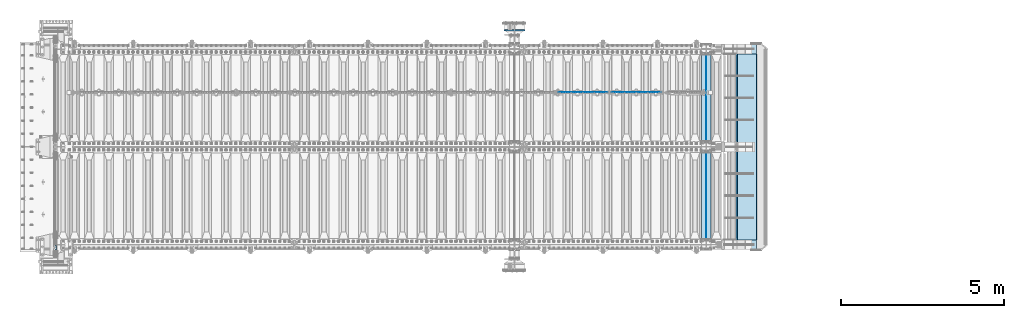
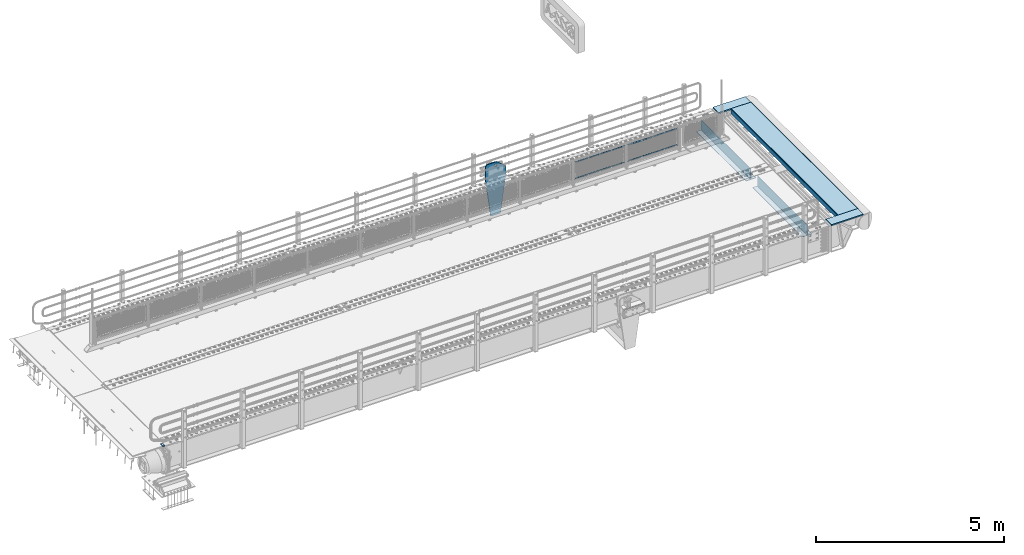
# One storey, part 194 of 242: 14 plates.
"""IFC2X3 building model written with IfcOpenShell, lengths in millimetres."""

from ifc_helpers import new_model, si_unit, frame, origin_with_axes, place, context, subcontext, project, spatial, faceted_brep, material, type_object, element, save


model = new_model("IFC2X3")

# Units and contexts
model_context = context("Model", 3, precision=1e-05, world=origin_with_axes())
body_context = subcontext(model_context, "Body", "Model", "MODEL_VIEW")
ifc_project = project(units=[si_unit("LENGTHUNIT", "METRE", prefix="MILLI"), si_unit("AREAUNIT", "SQUARE_METRE"), si_unit("VOLUMEUNIT", "CUBIC_METRE"), si_unit("MASSUNIT", "GRAM", prefix="KILO"), si_unit("TIMEUNIT", "SECOND"), si_unit("PLANEANGLEUNIT", "RADIAN"), si_unit("SOLIDANGLEUNIT", "STERADIAN"), si_unit("THERMODYNAMICTEMPERATUREUNIT", "DEGREE_CELSIUS"), si_unit("LUMINOUSINTENSITYUNIT", "LUMEN")], contexts=[model_context])

# Site, building, storey
site_placement = place(None, origin_with_axes())
site = spatial("IfcSite", under=ifc_project, at=site_placement, CompositionType="ELEMENT")
building_placement = place(site_placement, origin_with_axes())
building = spatial("IfcBuilding", under=site, at=building_placement, Name="Standard", CompositionType="ELEMENT")
storey_placement = place(building_placement, origin_with_axes())
storey = spatial("IfcBuildingStorey", under=building, at=storey_placement, Name="Undefined", CompositionType="ELEMENT", Elevation=0.0)

# Plates
ifc_material_1 = material()
plate_type_1 = type_object("IfcPlateType", PredefinedType="NOTDEFINED")
plate_1_placement = place(storey_placement, frame((-42460.00000006, -24089.9999995681, -15.9997623857934), z_axis=(-1.0, 0.0, 0.0), x_axis=(0.0, -4.95099997756316e-06, 0.999999999987744)))
element("IfcPlate", 1, at=plate_1_placement, inside=storey, type_object=plate_type_1, material=ifc_material_1, context=body_context, shape_type="Brep", body=[
    faceted_brep([(-1.77635683940025e-15, -60.0, 0.0), (-0.000933120085690575, -60.0, 60.0), (-0.000933120085690575, 60.0, 59.9999999999927), (-1.77635683940025e-15, 60.0, -7.27595761418343e-12), (24.9991450303709, -60.0, 60.0), (24.9991450303709, 60.0, 59.9999999999927), (26.544215218168, -60.0000000000036, 59.7552873850873), (26.544215218168, 60.0, 59.75528738508), (27.9380461396139, -60.0000000000036, 59.0451032459096), (27.9380461396139, 60.0, 59.0451032459096), (29.0442025908961, -60.0000000000036, 57.9389639895744), (29.0442025908961, 60.0, 57.9389639895744), (29.7544083969366, -60.0, 56.5451441080368), (29.7544083969366, 60.0, 56.5451441080295), (29.9991450297669, -60.0000000000036, 55.0000777244568), (29.9991450297669, 60.0, 55.0000777244495), (29.999922274335, -60.0, 5.00007772445679), (29.999922274335, 59.9999999999964, 5.00007772444951), (29.7552240705896, -60.0, 3.45497416452417), (29.7552240705896, 60.0000000000036, 3.45497416452417), (29.0450346578116, -60.0, 2.06111146690819), (29.0450346578116, 59.9999999999964, 2.06111146690819), (27.9388736885072, -60.0000000000036, 0.954933302316931), (27.9388736885072, 59.9999999999964, 0.954933302316931), (26.5450220308766, -60.0000000000036, 0.244722222181736), (26.5450220308766, 60.0, 0.244722222181736), (24.9999222749392, -60.0, 0.0), (24.9999222749392, 60.0, -7.27595761418343e-12)], [[[0, 1, 2, 3]], [[1, 4, 5, 2]], [[4, 6, 7, 5]], [[6, 8, 9, 7]], [[8, 10, 11, 9]], [[10, 12, 13, 11]], [[12, 14, 15, 13]], [[14, 16, 17, 15]], [[16, 18, 19, 17]], [[18, 20, 21, 19]], [[20, 22, 23, 21]], [[22, 24, 25, 23]], [[24, 26, 27, 25]], [[26, 0, 3, 27]], [[5, 7, 9, 11, 13, 15, 17, 19, 21, 23, 25, 27, 3, 2]], [[26, 24, 22, 20, 18, 16, 14, 12, 10, 8, 6, 4, 1, 0]]]),
])
ifc_material_2 = material(Name="Misc_Undefined")
plate_type_2 = type_object("IfcPlateType", PredefinedType="NOTDEFINED")
plate_2_placement = place(storey_placement, frame((-25445.4949882696, -19329.5, 351.520303374641), z_axis=(0.0, 0.0, 1.0), x_axis=(1.0, 0.0, 0.0)))
element("IfcPlate", 2, at=plate_2_placement, inside=storey, type_object=plate_type_2, material=ifc_material_2, context=body_context, shape_type="Brep", body=[
    faceted_brep([(0.0, -1.50000000000364, 0.0), (35.0002975463867, -1.5, 34.9996948242188), (35.0002975463867, 1.5, 34.9996948242188), (-3.63797880709171e-12, 1.49999999999636, 0.0), (1490.99035644531, -1.5, 34.9999923706055), (1490.99035644531, 1.5, 34.9999923706055), (1525.98999023438, -1.5, 2.81374923361e-11), (1525.98999023438, 1.5, 2.81374923361e-11)], [[[0, 1, 2, 3]], [[1, 4, 5, 2]], [[4, 6, 7, 5]], [[6, 0, 3, 7]], [[5, 7, 3, 2]], [[6, 4, 1, 0]]]),
])
plate_3_placement = place(storey_placement, frame((-23919.4999998124, -19329.5, 914.520000175701), z_axis=(-0.707103624179499, 0.0, 0.707109938179501), x_axis=(-0.707109938179495, 0.0, -0.707103624179505)))
element("IfcPlate", 3, at=plate_3_placement, inside=storey, type_object=plate_type_2, material=ifc_material_2, context=body_context, shape_type="Brep", body=[
    faceted_brep([(0.0, -1.50000000000364, 0.0), (1079.04980468751, -1.5, 1079.04028320313), (1079.04980468751, 1.5, 1079.04028320313), (-3.63797880709171e-12, 1.49999999999636, 0.0), (1079.04272460939, -1.5, 1029.53576660157), (1079.04272460939, 1.5, 1029.53576660157), (49.4976959228534, -1.5, -3.63797880709171e-12), (49.4976959228534, 1.5, -3.63797880709171e-12)], [[[0, 1, 2, 3]], [[1, 4, 5, 2]], [[4, 6, 7, 5]], [[6, 0, 3, 7]], [[5, 7, 3, 2]], [[6, 4, 1, 0]]]),
])
plate_4_placement = place(storey_placement, frame((-27078.4949882696, -19329.5, 351.520303374641), z_axis=(0.0, 0.0, 1.0), x_axis=(1.0, 0.0, 0.0)))
element("IfcPlate", 4, at=plate_4_placement, inside=storey, type_object=plate_type_2, material=ifc_material_2, context=body_context, shape_type="Brep", body=[
    faceted_brep([(0.0, -1.50000000000364, 0.0), (35.0002975463867, -1.5, 34.9996948242188), (35.0002975463867, 1.5, 34.9996948242188), (-3.63797880709171e-12, 1.49999999999636, 0.0), (1490.99035644531, -1.5, 34.9999923706055), (1490.99035644531, 1.5, 34.9999923706055), (1525.98999023438, -1.5, 2.81374923361e-11), (1525.98999023438, 1.5, 2.81374923361e-11)], [[[0, 1, 2, 3]], [[1, 4, 5, 2]], [[4, 6, 7, 5]], [[6, 0, 3, 7]], [[5, 7, 3, 2]], [[6, 4, 1, 0]]]),
])
plate_5_placement = place(storey_placement, frame((-25552.4999998124, -19329.5, 914.520000175701), z_axis=(-0.707103624179499, 0.0, 0.707109938179501), x_axis=(-0.707109938179495, 0.0, -0.707103624179505)))
element("IfcPlate", 5, at=plate_5_placement, inside=storey, type_object=plate_type_2, material=ifc_material_2, context=body_context, shape_type="Brep", body=[
    faceted_brep([(0.0, -1.50000000000364, 0.0), (1079.04980468751, -1.5, 1079.04028320313), (1079.04980468751, 1.5, 1079.04028320313), (-3.63797880709171e-12, 1.49999999999636, 0.0), (1079.04272460939, -1.5, 1029.53576660157), (1079.04272460939, 1.5, 1029.53576660157), (49.4976959228534, -1.5, -3.63797880709171e-12), (49.4976959228534, 1.5, -3.63797880709171e-12)], [[[0, 1, 2, 3]], [[1, 4, 5, 2]], [[4, 6, 7, 5]], [[6, 0, 3, 7]], [[5, 7, 3, 2]], [[6, 4, 1, 0]]]),
])
ifc_material_3 = material(Name="STEEL/S355N")
plate_type_3 = type_object("IfcPlateType", PredefinedType="NOTDEFINED")
plate_6_placement = place(storey_placement, frame((-28265.0000000603, -17419.9999999654, -1480.00001822199), z_axis=(0.0, 0.0, 1.0), x_axis=(-1.0, 0.0, 0.0)))
element("IfcPlate", 6, at=plate_6_placement, inside=storey, type_object=plate_type_3, material=ifc_material_3, context=body_context, shape_type="Brep", body=[
    faceted_brep([(113.04481869996, -15.0, 1615.3073372946), (113.04481869996, 14.9999999999527, 1615.3073372946), (121.715728752948, 14.9999999999527, 1628.28427124746), (121.715728752948, -15.0, 1628.28427124746), (134.692662705809, 14.9999999999527, 1636.95518130045), (134.692662705809, -15.0, 1636.95518130045), (150.000000000411, 14.9999999999527, 1640.0), (150.000000000411, -15.0, 1640.0), (165.307337295013, 14.9999999999527, 1636.95518130045), (165.307337295013, -15.0, 1636.95518130045), (178.284271247874, 14.9999999999527, 1628.28427124746), (178.284271247874, -15.0, 1628.28427124746), (186.955181300862, 14.9999999999527, 1615.3073372946), (186.955181300862, -15.0, 1615.3073372946), (190.000000000411, 14.9999999999527, 1600.0), (190.000000000411, -15.0, 1600.0), (186.955181300862, 14.9999999999527, 1584.6926627054), (186.955181300862, -15.0, 1584.6926627054), (178.284271247874, 14.9999999999527, 1571.71572875254), (178.284271247874, -15.0, 1571.71572875254), (165.307337295013, 14.9999999999527, 1563.04481869955), (165.307337295013, -15.0, 1563.04481869955), (150.000000000411, 14.9999999999527, 1560.0), (150.000000000411, -15.0, 1560.0), (134.692662705809, 14.9999999999527, 1563.04481869955), (134.692662705809, -15.0, 1563.04481869955), (121.715728752948, 14.9999999999527, 1571.71572875254), (121.715728752948, -15.0, 1571.71572875254), (113.04481869996, 14.9999999999527, 1584.6926627054), (113.04481869996, -15.0, 1584.6926627054), (110.000000000411, 14.9999999999527, 1600.0), (110.000000000411, -15.0, 1600.0), (300.0, -15.0, 0.0), (0.0, -15.0, 0.0), (0.0, 15.0, 0.0), (300.0, 15.0, 0.0), (462.5, -15.0, 1210.0), (462.5, 15.0, 1210.0), (462.5, -15.0, 1630.0), (462.5, 15.0, 1630.0), (459.774066103124, -15.0, 1650.7055236082), (459.774066103124, 15.0, 1650.7055236082), (451.782032302755, -15.0, 1670.0), (451.782032302755, 15.0, 1670.0), (439.068542494922, -15.0, 1686.56854249492), (439.068542494922, 15.0, 1686.56854249492), (422.5, -15.0, 1699.28203230276), (422.5, 15.0, 1699.28203230276), (403.205523608201, -15.0, 1707.27406610313), (403.205523608201, 15.0, 1707.27406610313), (382.5, -15.0, 1710.0), (382.5, 15.0, 1710.0), (151.788081037081, -15.0, 1710.0), (151.788081037081, 15.0, 1710.0), (132.694887325029, -15.0, 1708.33028179541), (132.694887325029, 15.0, 1708.33028179541), (114.181334578883, -15.0, 1703.37181734316), (114.181334578883, 15.0, 1703.37181734316), (96.809466726856, -15.0, 1695.27513824985), (96.809466726856, 15.0, 1695.27513824985), (81.1066678416755, -15.0, 1684.28604765144), (81.1066678416755, 15.0, 1684.28604765144), (-162.5, -15.0, 1480.0), (-162.5, 15.0, 1480.0), (-162.5, -15.0, 1210.0), (-162.5, 15.0, 1210.0), (150.000000000411, -15.0000000000036, 1551.5), (154.596194078124, -15.0000000000036, 1549.59619407771), (156.500000000411, -15.0000000000036, 1545.0), (154.596194078124, -15.0000000000036, 1540.40380592229), (150.000000000411, -15.0000000000036, 1538.5), (145.403805922699, -15.0000000000036, 1540.40380592229), (143.500000000411, -15.0000000000036, 1545.0), (145.403805922699, -15.0000000000036, 1549.59619407771), (150.000000000411, 14.9999999999964, 1538.5), (145.403805922699, 14.9999999999964, 1540.40380592229), (154.596194078124, 14.9999999999964, 1540.40380592229), (156.500000000411, 14.9999999999964, 1545.0), (154.596194078124, 14.9999999999964, 1549.59619407771), (150.000000000411, 14.9999999999964, 1551.5), (145.403805922699, 14.9999999999964, 1549.59619407771), (143.500000000411, 14.9999999999964, 1545.0)], [[[0, 1, 2, 3]], [[3, 2, 4, 5]], [[5, 4, 6, 7]], [[7, 6, 8, 9]], [[9, 8, 10, 11]], [[11, 10, 12, 13]], [[13, 12, 14, 15]], [[15, 14, 16, 17]], [[17, 16, 18, 19]], [[19, 18, 20, 21]], [[21, 20, 22, 23]], [[23, 22, 24, 25]], [[25, 24, 26, 27]], [[27, 26, 28, 29]], [[29, 28, 30, 31]], [[31, 30, 1, 0]], [[32, 33, 34, 35]], [[36, 32, 35, 37]], [[38, 36, 37, 39]], [[40, 38, 39, 41]], [[42, 40, 41, 43]], [[44, 42, 43, 45]], [[46, 44, 45, 47]], [[48, 46, 47, 49]], [[50, 48, 49, 51]], [[52, 50, 51, 53]], [[54, 52, 53, 55]], [[56, 54, 55, 57]], [[58, 56, 57, 59]], [[60, 58, 59, 61]], [[62, 60, 61, 63]], [[64, 62, 63, 65]], [[33, 64, 65, 34]], [[32, 36, 38, 40, 42, 44, 46, 48, 50, 52, 54, 56, 58, 60, 62, 64, 33], [3, 5, 7, 9, 11, 13, 15, 17, 19, 21, 23, 25, 27, 29, 31, 0], [66, 67, 68, 69, 70, 71, 72, 73]], [[70, 74, 75, 71]], [[69, 76, 74, 70]], [[68, 77, 76, 69]], [[67, 78, 77, 68]], [[66, 79, 78, 67]], [[73, 80, 79, 66]], [[72, 81, 80, 73]], [[71, 75, 81, 72]], [[63, 61, 59, 57, 55, 53, 51, 49, 47, 45, 43, 41, 39, 37, 35, 34, 65], [26, 24, 22, 20, 18, 16, 14, 12, 10, 8, 6, 4, 2, 1, 30, 28], [74, 76, 77, 78, 79, 80, 81, 75]]]),
])
plate_type_4 = type_object("IfcPlateType", PredefinedType="NOTDEFINED")
for number, where, z_axis, x_axis in (
    (7, (-22532.0, -18175.0, 0.0), (0.0, 0.0, -1.0), (0.0, -1.0, 0.0)),
    (8, (-22532.0, -21175.0, 0.0), (0.0, 0.0, -1.0), (0.0, -1.0, 0.0)),
):
    element("IfcPlate", number, at=place(storey_placement, frame(where, z_axis=z_axis, x_axis=x_axis)), inside=storey, type_object=plate_type_4, material=ifc_material_3, context=body_context, shape_type="Brep", body=[
        faceted_brep([(0.0, -5.0, 0.0), (0.0, -5.0, 336.0), (0.0, 5.0, 336.0), (0.0, 5.0, 0.0), (2650.0, -5.0, 336.0), (2650.0, 5.0, 336.0), (2650.0, -5.0, 0.0), (2650.0, 5.0, 0.0)], [[[0, 1, 2, 3]], [[1, 4, 5, 2]], [[4, 6, 7, 5]], [[6, 0, 3, 7]], [[5, 7, 3, 2]], [[6, 4, 1, 0]]]),
    ])
plate_type_5 = type_object("IfcPlateType", PredefinedType="NOTDEFINED")
for number, where, z_axis, x_axis in (
    (9, (-22682.0, -20825.0, -343.0), (0.0, 1.0, 0.0), (1.0, 0.0, 0.0)),
    (10, (-22682.0, -23825.0, -343.0), (0.0, 1.0, 0.0), (1.0, 0.0, 0.0)),
):
    element("IfcPlate", number, at=place(storey_placement, frame(where, z_axis=z_axis, x_axis=x_axis)), inside=storey, type_object=plate_type_5, material=ifc_material_3, context=body_context, shape_type="Brep", body=[
        faceted_brep([(0.0, -7.0, 0.0), (0.0, -7.0, 2650.0), (0.0, 7.0, 2650.0), (0.0, 7.0, 0.0), (300.0, -7.0, 2650.0), (300.0, 7.0, 2650.0), (300.0, -7.0, 0.0), (300.0, 7.0, 0.0)], [[[0, 1, 2, 3]], [[1, 4, 5, 2]], [[4, 6, 7, 5]], [[6, 0, 3, 7]], [[5, 7, 3, 2]], [[6, 4, 1, 0]]]),
    ])
plate_type_6 = type_object("IfcPlateType", PredefinedType="NOTDEFINED")
for number, where, z_axis, x_axis in (
    (11, (-21980.0011701094, -23850.0, -10.0000000001684), (1.0, 0.0, 0.0), (0.0, -1.0, 0.0)),
    (12, (-21980.0011701095, -17850.0, -10.0000000004865), (1.0, 0.0, 0.0), (0.0, -1.0, 0.0)),
):
    element("IfcPlate", number, at=place(storey_placement, frame(where, z_axis=z_axis, x_axis=x_axis)), inside=storey, type_object=plate_type_6, material=ifc_material_3, context=body_context, shape_type="Brep", body=[
        faceted_brep([(300.0, 7.0, 986.0), (300.0, 20.0, 956.0), (-3.63797880709171e-11, 20.0, 956.0), (-3.63797880709171e-11, 7.0, 986.0), (0.0, 20.0, 0.0), (0.0, -20.0, 0.0), (-3.63797880709171e-11, -20.0, 986.0), (300.0, -20.0, 986.0), (300.0, -20.0, 3.63797880709171e-12), (300.0, 20.0, 3.63797880709171e-12)], [[[0, 1, 2, 3]], [[4, 5, 6, 3, 2]], [[6, 7, 0, 3]], [[7, 8, 9, 1, 0]], [[8, 5, 4, 9]], [[9, 4, 2, 1]], [[8, 7, 6, 5]]]),
    ])
plate_type_7 = type_object("IfcPlateType", PredefinedType="NOTDEFINED")
plate_7_placement = place(storey_placement, frame((-21586.4454489358, -18149.9999999984, -155.274111776635), z_axis=(0.0, -1.0, 0.0), x_axis=(-0.0871556999853764, 0.0, 0.99619470183296)))
element("IfcPlate", 13, at=plate_7_placement, inside=storey, type_object=plate_type_7, material=ifc_material_3, context=body_context, shape_type="Brep", body=[
    faceted_brep([(0.0, -10.0, 0.0), (6.82121026329696e-13, -9.99999999999636, 5700.0), (4.54747350886464e-13, 10.0, 5700.0), (0.0, 10.0, 0.0), (155.0, -9.99999999999272, 5700.0), (155.0, 10.0, 5700.0), (155.0, -9.99999999999272, 0.0), (155.0, 10.0, 0.0)], [[[0, 1, 2, 3]], [[1, 4, 5, 2]], [[4, 6, 7, 5]], [[6, 0, 3, 7]], [[5, 7, 3, 2]], [[6, 4, 1, 0]]]),
])
plate_type_8 = type_object("IfcPlateType", PredefinedType="NOTDEFINED")
plate_8_placement = place(storey_placement, frame((-21589.997031974, -18149.9999999985, 0.00398537333359705), z_axis=(0.999999999979944, 6.49000001417961e-07, -6.29999999987365e-06), x_axis=(0.0, -1.0, 0.0)))
element("IfcPlate", 14, at=plate_8_placement, inside=storey, type_object=plate_type_8, material=ifc_material_3, context=body_context, shape_type="Brep", body=[
    faceted_brep([(5700.00047245354, -10.0, 596.995666503903), (5700.00048828125, 5.77093928200156e-13, 616.995666503906), (0.000205278949579224, 5.75844927297453e-13, 616.995788574215), (0.000198624802578706, -10.0, 596.995788574215), (0.000205278949579224, 10.0, 616.995788574215), (0.0, 10.0, 0.0), (0.0, -10.0, 0.0), (5700.00048828125, 10.0, 616.995666503906), (5700.0, -10.0, 2.17187334783375e-09), (5700.0, 10.0, 2.17551132664084e-09)], [[[0, 1, 2, 3]], [[4, 5, 6, 3, 2]], [[7, 4, 2, 1]], [[8, 9, 7, 1, 0]], [[8, 6, 5, 9]], [[7, 9, 5, 4]], [[6, 8, 0, 3]]]),
])

save(model, "model.ifc")
